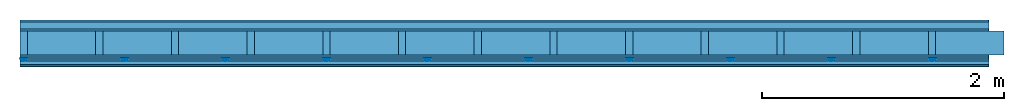
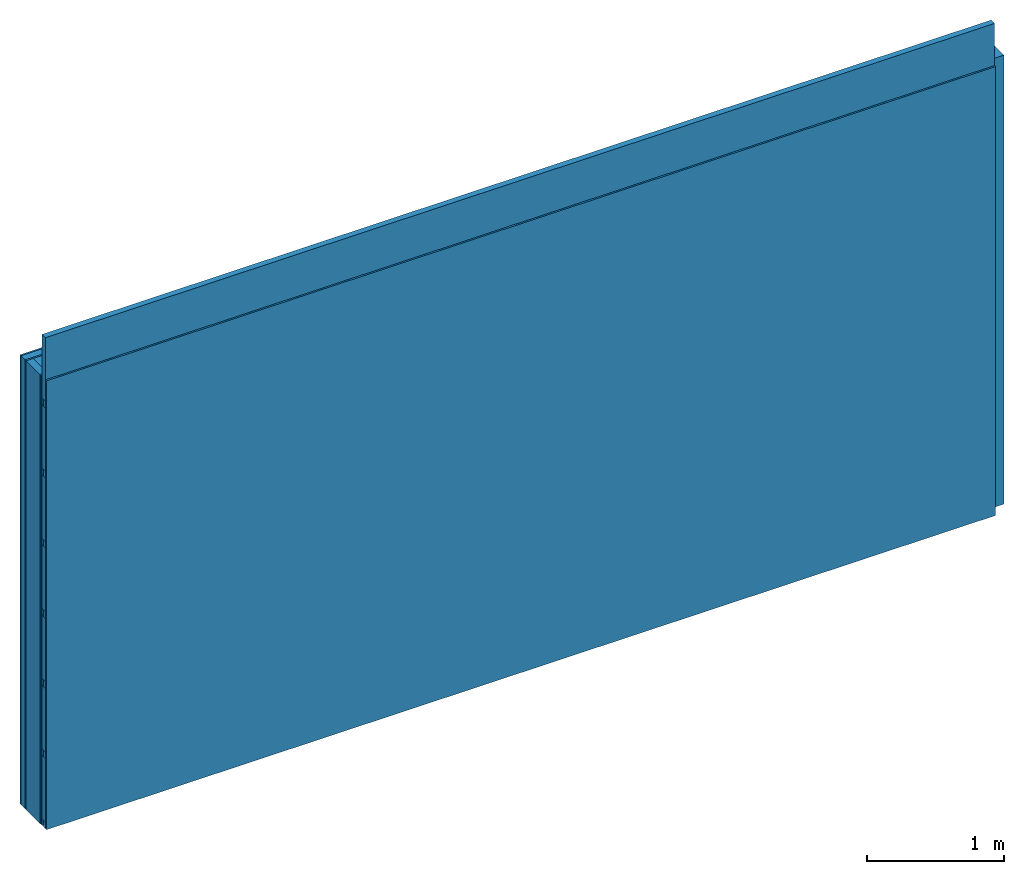
# One storey: 6 plates, 5 members, 1 element without a shape of its own.
"""IFC4 building model written with IfcOpenShell, lengths in metres."""

import ifcopenshell
import ifcopenshell.guid

model = None  # the IFC model being written
_history = None  # IfcOwnerHistory: only IFC2X3 demands one
_inside = {}  # id of a spatial element -> (the spatial element, [elements in it])
_under = {}  # id of a project, library or spatial element -> (it, [spatial elements below it])
_declared = {}  # id of a project -> (the project, [libraries it declares])
_typed = {}  # id of a type object -> (the type object, [elements of that type])
_made_of = {}  # id of a material, layer set ... -> (it, [elements and type objects made of it])


def new_model(schema):
    """Start an empty IFC model of exactly this schema.

    Asked for "IFC4X3", IfcOpenShell would pick the latest addendum, in which some entities
    have other attributes; the version numbers below select the first issue.
    IFC2X3 requires an IfcOwnerHistory on every rooted entity: one is made here for all.
    """
    global model, _history
    if schema == "IFC4X3":
        model = ifcopenshell.file(schema_version=(4, 3, 0, 0))
    else:
        model = ifcopenshell.file(schema=schema)
    _inside.clear()
    _under.clear()
    _declared.clear()
    _typed.clear()
    _made_of.clear()
    _history = None
    if model.schema == "IFC2X3":
        org = make("IfcOrganization", Name="unknown")
        user = make(
            "IfcPersonAndOrganization",
            ThePerson=make("IfcPerson", FamilyName="unknown"),
            TheOrganization=org,
        )
        app = make(
            "IfcApplication",
            ApplicationDeveloper=org,
            Version="unknown",
            ApplicationFullName="unknown",
            ApplicationIdentifier="unknown",
        )
        _history = make(
            "IfcOwnerHistory",
            OwningUser=user,
            OwningApplication=app,
            ChangeAction="ADDED",
            CreationDate=0,
        )
    return model


def make(cls, **values):
    """One entity of the class cls with the attributes given. An attribute that is None is left unset."""
    return model.create_entity(
        cls, **{name: value for name, value in values.items() if value is not None}
    )


def rooted(cls, **values):
    """An entity with a GlobalId (a new one), such as an element, a storey or a relation."""
    return make(cls, GlobalId=ifcopenshell.guid.new(), OwnerHistory=_history, **values)


def si_unit(unit_type, name, prefix=None):
    """IfcSIUnit, for example si_unit("LENGTHUNIT", "METRE", prefix="MILLI")."""
    return make("IfcSIUnit", UnitType=unit_type, Prefix=prefix, Name=name)


def derived_unit(unit_type, elements):
    """IfcDerivedUnit: a product of units, each with its exponent."""
    return make(
        "IfcDerivedUnit",
        Elements=[
            make("IfcDerivedUnitElement", Unit=unit, Exponent=power)
            for unit, power in elements
        ],
        UnitType=unit_type,
    )


def assignment(units):
    """IfcUnitAssignment: the units of a project."""
    return None if units is None else make("IfcUnitAssignment", Units=units)


def point(xyz):
    """IfcCartesianPoint."""
    return None if xyz is None else make("IfcCartesianPoint", Coordinates=xyz)


def direction(xyz):
    """IfcDirection."""
    return None if xyz is None else make("IfcDirection", DirectionRatios=xyz)


def frame(location, z_axis=None, x_axis=None):
    """IfcAxis2Placement3D, a coordinate frame: its origin and axes. An axis left out is left unset."""
    return make(
        "IfcAxis2Placement3D",
        Location=point(location),
        Axis=direction(z_axis),
        RefDirection=direction(x_axis),
    )


def frame_2d(location, x_axis=None):
    """IfcAxis2Placement2D, a coordinate frame in the plane: its origin and x axis."""
    return make(
        "IfcAxis2Placement2D", Location=point(location), RefDirection=direction(x_axis)
    )


def origin():
    """The frame at (0, 0, 0) with its axes left unset."""
    return frame((0.0, 0.0, 0.0))


def origin_with_axes():
    """The frame at (0, 0, 0) with the z axis (0, 0, 1) and the x axis (1, 0, 0) written out."""
    return frame((0.0, 0.0, 0.0), z_axis=(0.0, 0.0, 1.0), x_axis=(1.0, 0.0, 0.0))


def place(relative_to, where):
    """IfcLocalPlacement: puts the frame where relative to a parent placement (None: the world)."""
    return make(
        "IfcLocalPlacement", PlacementRelTo=relative_to, RelativePlacement=where
    )


def context(
    kind, dimensions, precision=None, world=None, true_north=None, identifier=None
):
    """IfcGeometricRepresentationContext, for example the 3D "Model" context."""
    return make(
        "IfcGeometricRepresentationContext",
        ContextIdentifier=identifier,
        ContextType=kind,
        CoordinateSpaceDimension=dimensions,
        Precision=precision,
        WorldCoordinateSystem=world,
        TrueNorth=true_north,
    )


def project(units=None, contexts=None):
    """IfcProject with its units and contexts."""
    return rooted(
        "IfcProject",
        Name="project",
        RepresentationContexts=contexts,
        UnitsInContext=assignment(units),
    )


def spatial(cls, under=None, at=None, **own):
    """A site, building, storey or space (cls), placed at a placement, below another one or the project."""
    s = rooted(cls, ObjectPlacement=at, **own)
    if under is not None:
        _under.setdefault(under.id(), (under, []))[1].append(s)
    return s


def polyline(points):
    """IfcPolyline through the points."""
    return make("IfcPolyline", Points=[point(p) for p in points])


def profile(cls, at=None, kind="AREA", **sizes):
    """A parametric profile (cls). Its sizes go by their IFC names, for example OverallWidth=200.0."""
    return make(cls, ProfileType=kind, Position=at, **sizes)


def rectangle(**sizes):
    """IfcRectangleProfileDef."""
    return profile("IfcRectangleProfileDef", **sizes)


def outline(outer, holes=None, kind="AREA"):
    """IfcArbitraryClosedProfileDef: a profile drawn as a closed curve; with holes, ...WithVoids."""
    if holes is None:
        return make("IfcArbitraryClosedProfileDef", ProfileType=kind, OuterCurve=outer)
    return make(
        "IfcArbitraryProfileDefWithVoids",
        ProfileType=kind,
        OuterCurve=outer,
        InnerCurves=holes,
    )


def extrude(swept, where, along, depth):
    """IfcExtrudedAreaSolid: the profile swept, set in the frame where, extruded along a direction by depth."""
    return make(
        "IfcExtrudedAreaSolid",
        SweptArea=swept,
        Position=where,
        ExtrudedDirection=direction(along),
        Depth=depth,
    )


def shape(context_of_items, identifier, shape_type, items):
    """IfcShapeRepresentation: the items that make up one representation, for example the "Body"."""
    return make(
        "IfcShapeRepresentation",
        ContextOfItems=context_of_items,
        RepresentationIdentifier=identifier,
        RepresentationType=shape_type,
        Items=items,
    )


def material(Name=None, Category=None):
    """IfcMaterial."""
    return make("IfcMaterial", Name=Name, Category=Category)


def layer(
    of_material, thickness, ventilated=None, Name=None, Category=None, Priority=None
):
    """IfcMaterialLayer: one layer of a wall or slab, of a material (None: an air gap)."""
    return make(
        "IfcMaterialLayer",
        Material=of_material,
        LayerThickness=thickness,
        IsVentilated=ventilated,
        Name=Name,
        Category=Category,
        Priority=Priority,
    )


def layer_set(layers, Name=None):
    """IfcMaterialLayerSet."""
    return make("IfcMaterialLayerSet", MaterialLayers=layers, LayerSetName=Name)


def made_of(thing, what):
    """Note that an element or type object is made of a material, layer set ...; save() writes the relation."""
    if what is not None:
        _made_of.setdefault(what.id(), (what, []))[1].append(thing)
    return thing


def type_object(cls, material=None, **own):
    """A type object (cls), such as IfcWallType, which elements share."""
    return made_of(rooted(cls, **own), material)


def element(
    cls,
    number,
    at=None,
    inside=None,
    cuts=None,
    type_object=None,
    material=None,
    context=None,
    identifier="Body",
    shape_type=None,
    held_by="IfcProductDefinitionShape",
    body=None,
    shapes=None,
    **own,
):
    """One element of the class cls, such as IfcWall. Its Tag is "e" and its number.

    at: its placement. inside: the storey or other place that contains it. cuts: it is an
    opening in that element (IfcRelVoidsElement). A single representation is given by context,
    identifier, shape_type and body (its items); several are given by shapes. held_by: the class
    of the entity that holds the representations. save() writes the other relations.
    """
    e = rooted(cls, Tag="e%d" % number, ObjectPlacement=at, **own)
    if body is not None:
        shapes = [shape(context, identifier, shape_type, body)]
    if shapes is not None:
        e.Representation = make(held_by, Representations=shapes)
    if inside is not None:
        _inside.setdefault(inside.id(), (inside, []))[1].append(e)
    if cuts is not None:
        rooted(
            "IfcRelVoidsElement", RelatingBuildingElement=cuts, RelatedOpeningElement=e
        )
    if type_object is not None:
        _typed.setdefault(type_object.id(), (type_object, []))[1].append(e)
    return made_of(e, material)


def aggregate(whole, parts):
    """IfcRelAggregates: a whole, such as a stair, and the parts it consists of."""
    return rooted("IfcRelAggregates", RelatingObject=whole, RelatedObjects=parts)


def save(model, path):
    """Write the relations noted so far, then the file.

    IfcRelAggregates (storeys below a building ...), IfcRelContainedInSpatialStructure (elements
    in a storey), IfcRelDefinesByType, IfcRelAssociatesMaterial and IfcRelDeclares: one each for
    every whole, place, type object, material and project.
    """
    for whole, parts in _under.values():
        aggregate(whole, parts)
    for where, things in _inside.values():
        rooted(
            "IfcRelContainedInSpatialStructure",
            RelatedElements=things,
            RelatingStructure=where,
        )
    for kind, things in _typed.values():
        rooted("IfcRelDefinesByType", RelatedObjects=things, RelatingType=kind)
    for what, things in _made_of.values():
        rooted("IfcRelAssociatesMaterial", RelatedObjects=things, RelatingMaterial=what)
    for by, libraries in _declared.values():
        rooted("IfcRelDeclares", RelatingContext=by, RelatedDefinitions=libraries)
    model.write(path)


model = new_model("IFC4")

# Units and contexts
plan_context = context("Plan", 3, precision=1e-05, world=origin(), true_north=direction((0.0, 1.0)))
model_context = context("Model", 3, precision=1e-05, world=origin(), true_north=direction((0.0, 1.0)))
ifc_project = project(units=[si_unit("LENGTHUNIT", "METRE"), derived_unit("SOUNDPRESSUREUNIT", [(si_unit("PRESSUREUNIT", "PASCAL", prefix="MICRO"), 0)]), si_unit("ENERGYUNIT", "JOULE", prefix="MEGA"), si_unit("MASSUNIT", "GRAM", prefix="KILO"), derived_unit("THERMALTRANSMITTANCEUNIT", [(si_unit("POWERUNIT", "WATT"), 1), (si_unit("AREAUNIT", "SQUARE_METRE"), -1), (si_unit("THERMODYNAMICTEMPERATUREUNIT", "KELVIN"), -1)]), derived_unit("AREADENSITYUNIT", [(si_unit("MASSUNIT", "GRAM", prefix="KILO"), 1), (si_unit("AREAUNIT", "SQUARE_METRE"), -1)]), derived_unit("USERDEFINED", [(si_unit("ENERGYUNIT", "JOULE", prefix="MEGA"), 1), (si_unit("AREAUNIT", "SQUARE_METRE"), -1)])], contexts=[plan_context, model_context])

# Site, building, storey
site = spatial("IfcSite", under=ifc_project)
building_placement = place(None, origin())
building = spatial("IfcBuilding", under=site, at=building_placement)
storey_placement = place(building_placement, origin())
storey = spatial("IfcBuildingStorey", under=building, at=storey_placement)

# Wall, members, plates
ifc_material_1 = material(Category="04.011")
ifc_layer_1 = layer(ifc_material_1, 0.015, Name="Surface 1")
ifc_material_2 = material(Category="10.009")
ifc_layer_2 = layer(ifc_material_2, 0.06, Name="outside 2nd layer")
ifc_material_3 = material(Category="03.007")
ifc_layer_3 = layer(ifc_material_3, 0.015, Name="outside 1st layer")
ifc_material_4 = material(Name="of the art")
ifc_layer_4 = layer(ifc_material_4, 0.0, Name="Bond")
ifc_layer_5 = layer(None, 0.2, Name="Support")
ifc_layer_6 = layer(ifc_material_4, 0.0, Name="Bond")
ifc_material_5 = material(Category="07.013")
ifc_layer_7 = layer(ifc_material_5, 0.015, Name="1st layer")
ifc_layer_8 = layer(ifc_material_3, 0.015, Name="2nd layer")
ifc_layer_9 = layer(None, 0.02, Name="Coupling")
ifc_layer_10 = layer(None, 0.03, Name="Battens / profiles")
ifc_layer_11 = layer(ifc_material_3, 0.015, Name="Covering 1st layer")
ifc_material_6 = material(Name="Glued joints")
ifc_layer_12 = layer(ifc_material_6, 0.0, Name="Surface")
ifc_layer_set = layer_set([ifc_layer_1, ifc_layer_2, ifc_layer_3, ifc_layer_4, ifc_layer_5, ifc_layer_6, ifc_layer_7, ifc_layer_8, ifc_layer_9, ifc_layer_10, ifc_layer_11, ifc_layer_12])
wall_type = type_object("IfcWallType", Name="D0665", PredefinedType="NOTDEFINED", material=ifc_layer_set)
wall_placement = place(None, frame((0.0, 0.0, 0.0), z_axis=(0.0, -1.0, 0.0), x_axis=(1.0, 0.0, 0.0)))
wall = element("IfcWall", 1, at=wall_placement, inside=storey, type_object=wall_type, material=ifc_layer_set, Name="Wall #1")
ifc_material_7 = material()
member_1_placement = place(wall_placement, origin())
member_1 = element("IfcMember", 2, at=member_1_placement, material=ifc_material_7, Name="Support", context=plan_context, shape_type="SweptSolid", body=[
    extrude(rectangle(XDim=0.06, YDim=0.2, at=frame_2d((0.03, 0.1), x_axis=(1.0, 0.0))), frame((0.0, 4.0, 0.09), z_axis=(0.0, -1.0, 0.0), x_axis=(1.0, 0.0, 0.0)), (0.0, 0.0, 1.0), 4.0),
    extrude(rectangle(XDim=0.06, YDim=0.2, at=frame_2d((0.03, 0.1), x_axis=(1.0, 0.0))), frame((0.625, 4.0, 0.09), z_axis=(0.0, -1.0, 0.0), x_axis=(1.0, 0.0, 0.0)), (0.0, 0.0, 1.0), 4.0),
    extrude(rectangle(XDim=0.06, YDim=0.2, at=frame_2d((0.03, 0.1), x_axis=(1.0, 0.0))), frame((1.25, 4.0, 0.09), z_axis=(0.0, -1.0, 0.0), x_axis=(1.0, 0.0, 0.0)), (0.0, 0.0, 1.0), 4.0),
    extrude(rectangle(XDim=0.06, YDim=0.2, at=frame_2d((0.03, 0.1), x_axis=(1.0, 0.0))), frame((1.875, 4.0, 0.09), z_axis=(0.0, -1.0, 0.0), x_axis=(1.0, 0.0, 0.0)), (0.0, 0.0, 1.0), 4.0),
    extrude(rectangle(XDim=0.06, YDim=0.2, at=frame_2d((0.03, 0.1), x_axis=(1.0, 0.0))), frame((2.5, 4.0, 0.09), z_axis=(0.0, -1.0, 0.0), x_axis=(1.0, 0.0, 0.0)), (0.0, 0.0, 1.0), 4.0),
    extrude(rectangle(XDim=0.06, YDim=0.2, at=frame_2d((0.03, 0.1), x_axis=(1.0, 0.0))), frame((3.125, 4.0, 0.09), z_axis=(0.0, -1.0, 0.0), x_axis=(1.0, 0.0, 0.0)), (0.0, 0.0, 1.0), 4.0),
    extrude(rectangle(XDim=0.06, YDim=0.2, at=frame_2d((0.03, 0.1), x_axis=(1.0, 0.0))), frame((3.75, 4.0, 0.09), z_axis=(0.0, -1.0, 0.0), x_axis=(1.0, 0.0, 0.0)), (0.0, 0.0, 1.0), 4.0),
    extrude(rectangle(XDim=0.06, YDim=0.2, at=frame_2d((0.03, 0.1), x_axis=(1.0, 0.0))), frame((4.375, 4.0, 0.09), z_axis=(0.0, -1.0, 0.0), x_axis=(1.0, 0.0, 0.0)), (0.0, 0.0, 1.0), 4.0),
    extrude(rectangle(XDim=0.06, YDim=0.2, at=frame_2d((0.03, 0.1), x_axis=(1.0, 0.0))), frame((5.0, 4.0, 0.09), z_axis=(0.0, -1.0, 0.0), x_axis=(1.0, 0.0, 0.0)), (0.0, 0.0, 1.0), 4.0),
    extrude(rectangle(XDim=0.06, YDim=0.2, at=frame_2d((0.03, 0.1), x_axis=(1.0, 0.0))), frame((5.625, 4.0, 0.09), z_axis=(0.0, -1.0, 0.0), x_axis=(1.0, 0.0, 0.0)), (0.0, 0.0, 1.0), 4.0),
    extrude(rectangle(XDim=0.06, YDim=0.2, at=frame_2d((0.03, 0.1), x_axis=(1.0, 0.0))), frame((6.25, 4.0, 0.09), z_axis=(0.0, -1.0, 0.0), x_axis=(1.0, 0.0, 0.0)), (0.0, 0.0, 1.0), 4.0),
    extrude(rectangle(XDim=0.06, YDim=0.2, at=frame_2d((0.03, 0.1), x_axis=(1.0, 0.0))), frame((6.875, 4.0, 0.09), z_axis=(0.0, -1.0, 0.0), x_axis=(1.0, 0.0, 0.0)), (0.0, 0.0, 1.0), 4.0),
    extrude(rectangle(XDim=0.06, YDim=0.2, at=frame_2d((0.03, 0.1), x_axis=(1.0, 0.0))), frame((7.5, 4.0, 0.09), z_axis=(0.0, -1.0, 0.0), x_axis=(1.0, 0.0, 0.0)), (0.0, 0.0, 1.0), 4.0),
])
ifc_material_8 = material()
member_2_placement = place(wall_placement, origin())
member_2 = element("IfcMember", 3, at=member_2_placement, material=ifc_material_8, Name="Cavity", context=plan_context, shape_type="SweptSolid", body=[
    extrude(rectangle(XDim=0.565, YDim=0.2, at=frame_2d((0.2825, 0.1), x_axis=(1.0, 0.0))), frame((0.06, 4.0, 0.09), z_axis=(0.0, -1.0, 0.0), x_axis=(1.0, 0.0, 0.0)), (0.0, 0.0, 1.0), 4.0),
    extrude(rectangle(XDim=0.565, YDim=0.2, at=frame_2d((0.2825, 0.1), x_axis=(1.0, 0.0))), frame((0.685, 4.0, 0.09), z_axis=(0.0, -1.0, 0.0), x_axis=(1.0, 0.0, 0.0)), (0.0, 0.0, 1.0), 4.0),
    extrude(rectangle(XDim=0.565, YDim=0.2, at=frame_2d((0.2825, 0.1), x_axis=(1.0, 0.0))), frame((1.31, 4.0, 0.09), z_axis=(0.0, -1.0, 0.0), x_axis=(1.0, 0.0, 0.0)), (0.0, 0.0, 1.0), 4.0),
    extrude(rectangle(XDim=0.565, YDim=0.2, at=frame_2d((0.2825, 0.1), x_axis=(1.0, 0.0))), frame((1.935, 4.0, 0.09), z_axis=(0.0, -1.0, 0.0), x_axis=(1.0, 0.0, 0.0)), (0.0, 0.0, 1.0), 4.0),
    extrude(rectangle(XDim=0.565, YDim=0.2, at=frame_2d((0.2825, 0.1), x_axis=(1.0, 0.0))), frame((2.56, 4.0, 0.09), z_axis=(0.0, -1.0, 0.0), x_axis=(1.0, 0.0, 0.0)), (0.0, 0.0, 1.0), 4.0),
    extrude(rectangle(XDim=0.565, YDim=0.2, at=frame_2d((0.2825, 0.1), x_axis=(1.0, 0.0))), frame((3.185, 4.0, 0.09), z_axis=(0.0, -1.0, 0.0), x_axis=(1.0, 0.0, 0.0)), (0.0, 0.0, 1.0), 4.0),
    extrude(rectangle(XDim=0.565, YDim=0.2, at=frame_2d((0.2825, 0.1), x_axis=(1.0, 0.0))), frame((3.81, 4.0, 0.09), z_axis=(0.0, -1.0, 0.0), x_axis=(1.0, 0.0, 0.0)), (0.0, 0.0, 1.0), 4.0),
    extrude(rectangle(XDim=0.565, YDim=0.2, at=frame_2d((0.2825, 0.1), x_axis=(1.0, 0.0))), frame((4.435, 4.0, 0.09), z_axis=(0.0, -1.0, 0.0), x_axis=(1.0, 0.0, 0.0)), (0.0, 0.0, 1.0), 4.0),
    extrude(rectangle(XDim=0.565, YDim=0.2, at=frame_2d((0.2825, 0.1), x_axis=(1.0, 0.0))), frame((5.06, 4.0, 0.09), z_axis=(0.0, -1.0, 0.0), x_axis=(1.0, 0.0, 0.0)), (0.0, 0.0, 1.0), 4.0),
    extrude(rectangle(XDim=0.565, YDim=0.2, at=frame_2d((0.2825, 0.1), x_axis=(1.0, 0.0))), frame((5.685, 4.0, 0.09), z_axis=(0.0, -1.0, 0.0), x_axis=(1.0, 0.0, 0.0)), (0.0, 0.0, 1.0), 4.0),
    extrude(rectangle(XDim=0.565, YDim=0.2, at=frame_2d((0.2825, 0.1), x_axis=(1.0, 0.0))), frame((6.31, 4.0, 0.09), z_axis=(0.0, -1.0, 0.0), x_axis=(1.0, 0.0, 0.0)), (0.0, 0.0, 1.0), 4.0),
    extrude(rectangle(XDim=0.565, YDim=0.2, at=frame_2d((0.2825, 0.1), x_axis=(1.0, 0.0))), frame((6.935, 4.0, 0.09), z_axis=(0.0, -1.0, 0.0), x_axis=(1.0, 0.0, 0.0)), (0.0, 0.0, 1.0), 4.0),
    extrude(rectangle(XDim=0.565, YDim=0.2, at=frame_2d((0.2825, 0.1), x_axis=(1.0, 0.0))), frame((7.56, 4.0, 0.09), z_axis=(0.0, -1.0, 0.0), x_axis=(1.0, 0.0, 0.0)), (0.0, 0.0, 1.0), 4.0),
])
ifc_material_9 = material()
member_3_placement = place(wall_placement, origin())
member_3 = element("IfcMember", 4, at=member_3_placement, material=ifc_material_9, Name="Coupling", context=plan_context, shape_type="SweptSolid", body=[
    extrude(outline(polyline([(0.0, 0.0), (0.06, 0.0), (0.04, 0.02), (0.02, 0.02), (0.0, 0.0)])), frame((0.0, 4.0, 0.32), z_axis=(0.0, -1.0, 0.0), x_axis=(1.0, 0.0, 0.0)), (0.0, 0.0, 1.0), 4.0),
    extrude(outline(polyline([(0.0, 0.0), (0.06, 0.0), (0.04, 0.02), (0.02, 0.02), (0.0, 0.0)])), frame((0.834, 4.0, 0.32), z_axis=(0.0, -1.0, 0.0), x_axis=(1.0, 0.0, 0.0)), (0.0, 0.0, 1.0), 4.0),
    extrude(outline(polyline([(0.0, 0.0), (0.06, 0.0), (0.04, 0.02), (0.02, 0.02), (0.0, 0.0)])), frame((1.668, 4.0, 0.32), z_axis=(0.0, -1.0, 0.0), x_axis=(1.0, 0.0, 0.0)), (0.0, 0.0, 1.0), 4.0),
    extrude(outline(polyline([(0.0, 0.0), (0.06, 0.0), (0.04, 0.02), (0.02, 0.02), (0.0, 0.0)])), frame((2.502, 4.0, 0.32), z_axis=(0.0, -1.0, 0.0), x_axis=(1.0, 0.0, 0.0)), (0.0, 0.0, 1.0), 4.0),
    extrude(outline(polyline([(0.0, 0.0), (0.06, 0.0), (0.04, 0.02), (0.02, 0.02), (0.0, 0.0)])), frame((3.336, 4.0, 0.32), z_axis=(0.0, -1.0, 0.0), x_axis=(1.0, 0.0, 0.0)), (0.0, 0.0, 1.0), 4.0),
    extrude(outline(polyline([(0.0, 0.0), (0.06, 0.0), (0.04, 0.02), (0.02, 0.02), (0.0, 0.0)])), frame((4.17, 4.0, 0.32), z_axis=(0.0, -1.0, 0.0), x_axis=(1.0, 0.0, 0.0)), (0.0, 0.0, 1.0), 4.0),
    extrude(outline(polyline([(0.0, 0.0), (0.06, 0.0), (0.04, 0.02), (0.02, 0.02), (0.0, 0.0)])), frame((5.004, 4.0, 0.32), z_axis=(0.0, -1.0, 0.0), x_axis=(1.0, 0.0, 0.0)), (0.0, 0.0, 1.0), 4.0),
    extrude(outline(polyline([(0.0, 0.0), (0.06, 0.0), (0.04, 0.02), (0.02, 0.02), (0.0, 0.0)])), frame((5.838, 4.0, 0.32), z_axis=(0.0, -1.0, 0.0), x_axis=(1.0, 0.0, 0.0)), (0.0, 0.0, 1.0), 4.0),
    extrude(outline(polyline([(0.0, 0.0), (0.06, 0.0), (0.04, 0.02), (0.02, 0.02), (0.0, 0.0)])), frame((6.672, 4.0, 0.32), z_axis=(0.0, -1.0, 0.0), x_axis=(1.0, 0.0, 0.0)), (0.0, 0.0, 1.0), 4.0),
    extrude(outline(polyline([(0.0, 0.0), (0.06, 0.0), (0.04, 0.02), (0.02, 0.02), (0.0, 0.0)])), frame((7.506, 4.0, 0.32), z_axis=(0.0, -1.0, 0.0), x_axis=(1.0, 0.0, 0.0)), (0.0, 0.0, 1.0), 4.0),
])
member_4_placement = place(wall_placement, origin())
member_4 = element("IfcMember", 5, at=member_4_placement, material=ifc_material_9, Name="Battens / profiles", context=plan_context, shape_type="SweptSolid", body=[
    extrude(rectangle(XDim=0.06, YDim=0.03, at=frame_2d((0.03, 0.015), x_axis=(1.0, 0.0))), frame((0.0, 0.0, 0.34), z_axis=(1.0, 0.0, 0.0), x_axis=(0.0, 1.0, 0.0)), (0.0, 0.0, 1.0), 8.0),
    extrude(rectangle(XDim=0.06, YDim=0.03, at=frame_2d((0.03, 0.015), x_axis=(1.0, 0.0))), frame((0.0, 0.625, 0.34), z_axis=(1.0, 0.0, 0.0), x_axis=(0.0, 1.0, 0.0)), (0.0, 0.0, 1.0), 8.0),
    extrude(rectangle(XDim=0.06, YDim=0.03, at=frame_2d((0.03, 0.015), x_axis=(1.0, 0.0))), frame((0.0, 1.25, 0.34), z_axis=(1.0, 0.0, 0.0), x_axis=(0.0, 1.0, 0.0)), (0.0, 0.0, 1.0), 8.0),
    extrude(rectangle(XDim=0.06, YDim=0.03, at=frame_2d((0.03, 0.015), x_axis=(1.0, 0.0))), frame((0.0, 1.875, 0.34), z_axis=(1.0, 0.0, 0.0), x_axis=(0.0, 1.0, 0.0)), (0.0, 0.0, 1.0), 8.0),
    extrude(rectangle(XDim=0.06, YDim=0.03, at=frame_2d((0.03, 0.015), x_axis=(1.0, 0.0))), frame((0.0, 2.5, 0.34), z_axis=(1.0, 0.0, 0.0), x_axis=(0.0, 1.0, 0.0)), (0.0, 0.0, 1.0), 8.0),
    extrude(rectangle(XDim=0.06, YDim=0.03, at=frame_2d((0.03, 0.015), x_axis=(1.0, 0.0))), frame((0.0, 3.125, 0.34), z_axis=(1.0, 0.0, 0.0), x_axis=(0.0, 1.0, 0.0)), (0.0, 0.0, 1.0), 8.0),
    extrude(rectangle(XDim=0.06, YDim=0.03, at=frame_2d((0.03, 0.015), x_axis=(1.0, 0.0))), frame((0.0, 3.75, 0.34), z_axis=(1.0, 0.0, 0.0), x_axis=(0.0, 1.0, 0.0)), (0.0, 0.0, 1.0), 8.0),
])
member_5_placement = place(wall_placement, origin())
member_5 = element("IfcMember", 6, at=member_5_placement, material=ifc_material_8, Name="Cavity", context=plan_context, shape_type="SweptSolid", body=[
    extrude(rectangle(XDim=0.565, YDim=0.05, at=frame_2d((0.2825, 0.025), x_axis=(1.0, 0.0))), frame((0.0, 0.06, 0.32), z_axis=(1.0, 0.0, 0.0), x_axis=(0.0, 1.0, 0.0)), (0.0, 0.0, 1.0), 8.0),
    extrude(rectangle(XDim=0.565, YDim=0.05, at=frame_2d((0.2825, 0.025), x_axis=(1.0, 0.0))), frame((0.0, 0.685, 0.32), z_axis=(1.0, 0.0, 0.0), x_axis=(0.0, 1.0, 0.0)), (0.0, 0.0, 1.0), 8.0),
    extrude(rectangle(XDim=0.565, YDim=0.05, at=frame_2d((0.2825, 0.025), x_axis=(1.0, 0.0))), frame((0.0, 1.31, 0.32), z_axis=(1.0, 0.0, 0.0), x_axis=(0.0, 1.0, 0.0)), (0.0, 0.0, 1.0), 8.0),
    extrude(rectangle(XDim=0.565, YDim=0.05, at=frame_2d((0.2825, 0.025), x_axis=(1.0, 0.0))), frame((0.0, 1.935, 0.32), z_axis=(1.0, 0.0, 0.0), x_axis=(0.0, 1.0, 0.0)), (0.0, 0.0, 1.0), 8.0),
    extrude(rectangle(XDim=0.565, YDim=0.05, at=frame_2d((0.2825, 0.025), x_axis=(1.0, 0.0))), frame((0.0, 2.56, 0.32), z_axis=(1.0, 0.0, 0.0), x_axis=(0.0, 1.0, 0.0)), (0.0, 0.0, 1.0), 8.0),
    extrude(rectangle(XDim=0.565, YDim=0.05, at=frame_2d((0.2825, 0.025), x_axis=(1.0, 0.0))), frame((0.0, 3.185, 0.32), z_axis=(1.0, 0.0, 0.0), x_axis=(0.0, 1.0, 0.0)), (0.0, 0.0, 1.0), 8.0),
    extrude(rectangle(XDim=0.565, YDim=0.05, at=frame_2d((0.2825, 0.025), x_axis=(1.0, 0.0))), frame((0.0, 3.81, 0.32), z_axis=(1.0, 0.0, 0.0), x_axis=(0.0, 1.0, 0.0)), (0.0, 0.0, 1.0), 8.0),
])
plate_1_placement = place(wall_placement, origin())
plate_1 = element("IfcPlate", 7, at=plate_1_placement, material=ifc_material_1, Name="Surface 1", context=plan_context, shape_type="SweptSolid", body=[
    extrude(rectangle(XDim=8.0, YDim=4.0, at=frame_2d((4.0, 2.0), x_axis=(1.0, 0.0))), origin_with_axes(), (0.0, 0.0, 1.0), 0.015),
])
plate_2_placement = place(wall_placement, origin())
plate_2 = element("IfcPlate", 8, at=plate_2_placement, material=ifc_material_2, Name="outside 2nd layer", context=plan_context, shape_type="SweptSolid", body=[
    extrude(rectangle(XDim=8.0, YDim=4.0, at=frame_2d((4.0, 2.0), x_axis=(1.0, 0.0))), frame((0.0, 0.0, 0.015), z_axis=(0.0, 0.0, 1.0), x_axis=(1.0, 0.0, 0.0)), (0.0, 0.0, 1.0), 0.06),
])
plate_3_placement = place(wall_placement, origin())
plate_3 = element("IfcPlate", 9, at=plate_3_placement, material=ifc_material_3, Name="outside 1st layer", context=plan_context, shape_type="SweptSolid", body=[
    extrude(rectangle(XDim=8.0, YDim=4.0, at=frame_2d((4.0, 2.0), x_axis=(1.0, 0.0))), frame((0.0, 0.0, 0.075), z_axis=(0.0, 0.0, 1.0), x_axis=(1.0, 0.0, 0.0)), (0.0, 0.0, 1.0), 0.015),
])
plate_4_placement = place(wall_placement, origin())
plate_4 = element("IfcPlate", 10, at=plate_4_placement, material=ifc_material_5, Name="1st layer", context=plan_context, shape_type="SweptSolid", body=[
    extrude(rectangle(XDim=8.0, YDim=4.0, at=frame_2d((4.0, 2.0), x_axis=(1.0, 0.0))), frame((0.0, 0.0, 0.29), z_axis=(0.0, 0.0, 1.0), x_axis=(1.0, 0.0, 0.0)), (0.0, 0.0, 1.0), 0.015),
])
plate_5_placement = place(wall_placement, origin())
plate_5 = element("IfcPlate", 11, at=plate_5_placement, material=ifc_material_3, Name="2nd layer", context=plan_context, shape_type="SweptSolid", body=[
    extrude(rectangle(XDim=8.0, YDim=4.0, at=frame_2d((4.0, 2.0), x_axis=(1.0, 0.0))), frame((0.0, 0.0, 0.305), z_axis=(0.0, 0.0, 1.0), x_axis=(1.0, 0.0, 0.0)), (0.0, 0.0, 1.0), 0.015),
])
plate_6_placement = place(wall_placement, origin())
plate_6 = element("IfcPlate", 12, at=plate_6_placement, material=ifc_material_3, Name="Covering 1st layer", context=plan_context, shape_type="SweptSolid", body=[
    extrude(rectangle(XDim=8.0, YDim=4.0, at=frame_2d((4.0, 2.0), x_axis=(1.0, 0.0))), frame((0.0, 0.0, 0.37), z_axis=(0.0, 0.0, 1.0), x_axis=(1.0, 0.0, 0.0)), (0.0, 0.0, 1.0), 0.015),
])
aggregate(wall, [plate_1, plate_2, plate_3, member_1, member_2, plate_4, plate_5, member_3, member_4, member_5, plate_6])

save(model, "model.ifc")
